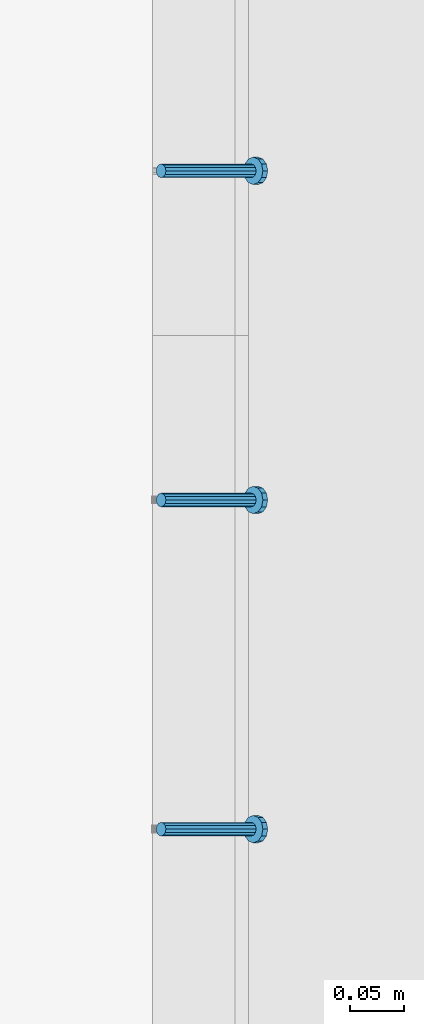
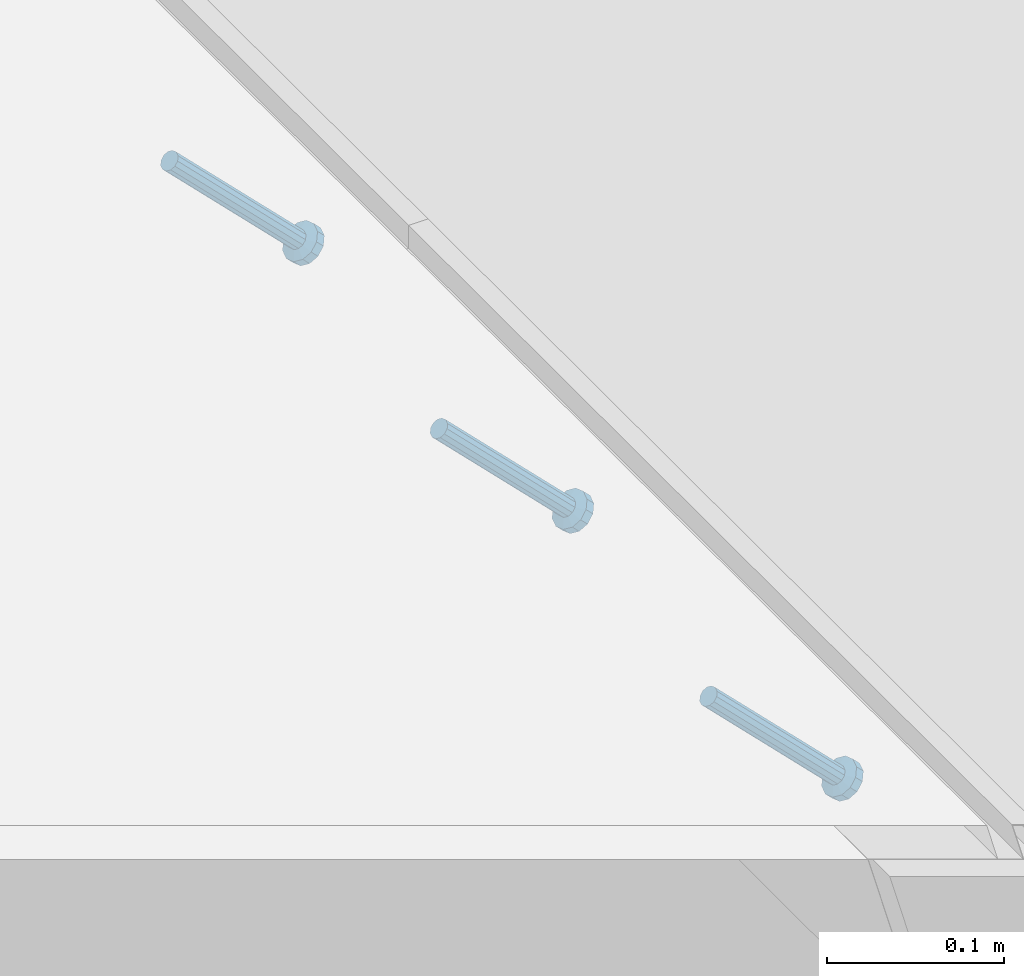
# One storey, part 2380 of 3843: 3 members, 2 elements without a shape of their own.
"""IFC2X3 building model written with IfcOpenShell, lengths in millimetres."""

from ifc_helpers import new_model, si_unit, frame, origin_with_axes, place, context, subcontext, project, spatial, faceted_brep, material, type_object, element, aggregate, save


model = new_model("IFC2X3")

# Units and contexts
model_context = context("Model", 3, precision=1e-05, world=origin_with_axes())
body_context = subcontext(model_context, "Body", "Model", "MODEL_VIEW")
ifc_project = project(units=[si_unit("LENGTHUNIT", "METRE", prefix="MILLI"), si_unit("AREAUNIT", "SQUARE_METRE"), si_unit("VOLUMEUNIT", "CUBIC_METRE"), si_unit("MASSUNIT", "GRAM", prefix="KILO"), si_unit("TIMEUNIT", "SECOND"), si_unit("PLANEANGLEUNIT", "RADIAN"), si_unit("SOLIDANGLEUNIT", "STERADIAN"), si_unit("THERMODYNAMICTEMPERATUREUNIT", "DEGREE_CELSIUS"), si_unit("LUMINOUSINTENSITYUNIT", "LUMEN")], contexts=[model_context])

# Site, building, storey
site_placement = place(None, origin_with_axes())
site = spatial("IfcSite", under=ifc_project, at=site_placement, CompositionType="ELEMENT")
building_placement = place(site_placement, origin_with_axes())
building = spatial("IfcBuilding", under=site, at=building_placement, Name="Undefined", CompositionType="ELEMENT")
storey_placement = place(building_placement, origin_with_axes())
storey = spatial("IfcBuildingStorey", under=building, at=storey_placement, Name="Undefined", CompositionType="ELEMENT", Elevation=0.0)

# Assembly, members
assembly_1_placement = place(storey_placement, origin_with_axes())
assembly_1 = element("IfcElementAssembly", 1, at=assembly_1_placement, inside=storey, Name="EMBED_ANGLE", AssemblyPlace="NOTDEFINED", PredefinedType="RIGID_FRAME")
ifc_material = material(Name="STEEL/A108")
member_type = type_object("IfcMemberType", PredefinedType="NOTDEFINED")
member_1_placement = place(assembly_1_placement, frame((44851.3834999999, 70869.175189209, 30456.1875), z_axis=(0.0, 1.0, 0.0), x_axis=(0.707106781186548, 0.0, -0.707106781186548)))
member_1 = element("IfcMember", 2, at=member_1_placement, type_object=member_type, material=ifc_material, Name="HEADED STUD ANCHOR", context=body_context, shape_type="Brep", body=[
    faceted_brep([(7.27595761418343e-12, -3.18000006675175, 5.5), (0.0, -5.49999999998363, 3.1800000667572), (118.110000000976, -5.49999999999091, 3.1800000667572), (118.110000000983, -3.18000006675175, 5.5), (0.0, -6.3499999046162, 0.0), (118.110000000968, -6.34999990461256, 0.0), (0.0, -5.49999999998363, -3.1800000667572), (118.110000000976, -5.49999999999091, -3.1800000667572), (7.27595761418343e-12, -3.18000006675175, -5.5), (118.110000000983, -3.18000006675175, -5.5), (7.27595761418343e-12, -1.81898940354586e-12, -6.34999990463257), (118.110000000968, -1.81898940354586e-12, -6.34999990463257), (0.0, 3.18000006675175, -5.5), (118.110000000968, 3.18000006674811, -5.5), (7.27595761418343e-12, 5.49999999998363, -3.1800000667572), (118.110000000983, 5.49999999998363, -3.1800000667572), (7.27595761418343e-12, 6.3499999046162, 0.0), (118.110000000976, 6.34999990461256, 0.0), (7.27595761418343e-12, 5.49999999998363, 3.1800000667572), (118.110000000983, 5.49999999998363, 3.1800000667572), (0.0, 3.18000006675175, 5.5), (118.110000000968, 3.18000006674811, 5.5), (7.27595761418343e-12, -1.81898940354586e-12, 6.34999990463257), (118.110000000968, -1.81898940354586e-12, 6.34999990463257), (120.650000000991, -10.9899997710909, 6.34999990463257), (120.650000000998, -6.34000015257152, 10.9899997711182), (120.650000000991, -12.6999998092379, 0.0), (120.650000000991, -10.9899997710909, -6.34999990463257), (120.650000000998, -6.34000015257152, -10.9899997711182), (120.650000000991, -1.81898940354586e-12, -12.6899995803833), (120.650000000991, 6.34000015257152, -10.9899997711182), (120.650000000998, 10.9899997710909, -6.34999990463257), (120.650000000991, 12.6999998092342, 0.0), (120.650000000998, 10.9899997710909, 6.34999990463257), (120.650000000991, 6.34000015257152, 10.9899997711182), (120.650000000991, -1.81898940354586e-12, 12.6899995803833), (127.000000001048, -10.9899997710945, 6.34999990463257), (127.000000001048, -6.34000015257152, 10.9899997711182), (127.000000001048, -12.6999998092342, 0.0), (127.000000001048, -10.9899997710945, -6.34999990463257), (127.000000001048, -6.34000015257152, -10.9899997711182), (127.000000001048, 1.81898940354586e-12, -12.6899995803833), (127.000000001048, 6.34000015256788, -10.9899997711182), (127.000000001048, 10.9899997710909, -6.34999990463257), (127.000000001048, 12.6999998092379, 0.0), (127.000000001048, 10.9899997710909, 6.34999990463257), (127.000000001048, 6.34000015256788, 10.9899997711182), (127.000000001048, 1.81898940354586e-12, 12.6899995803833)], [[[0, 1, 2, 3]], [[1, 4, 5, 2]], [[4, 6, 7, 5]], [[6, 8, 9, 7]], [[8, 10, 11, 9]], [[10, 12, 13, 11]], [[12, 14, 15, 13]], [[14, 16, 17, 15]], [[16, 18, 19, 17]], [[18, 20, 21, 19]], [[20, 22, 23, 21]], [[22, 0, 3, 23]], [[22, 20, 18, 16, 14, 12, 10, 8, 6, 4, 1, 0]], [[3, 2, 24, 25]], [[2, 5, 26, 24]], [[5, 7, 27, 26]], [[7, 9, 28, 27]], [[9, 11, 29, 28]], [[11, 13, 30, 29]], [[13, 15, 31, 30]], [[15, 17, 32, 31]], [[17, 19, 33, 32]], [[19, 21, 34, 33]], [[21, 23, 35, 34]], [[23, 3, 25, 35]], [[25, 24, 36, 37]], [[24, 26, 38, 36]], [[26, 27, 39, 38]], [[27, 28, 40, 39]], [[28, 29, 41, 40]], [[29, 30, 42, 41]], [[30, 31, 43, 42]], [[31, 32, 44, 43]], [[32, 33, 45, 44]], [[33, 34, 46, 45]], [[34, 35, 47, 46]], [[35, 25, 37, 47]], [[38, 39, 40, 41, 42, 43, 44, 45, 46, 47, 37, 36]]]),
])
member_2_placement = place(assembly_1_placement, frame((44851.3834999999, 71173.975189209, 30456.1875), z_axis=(0.0, 1.0, 0.0), x_axis=(0.707106781186548, 0.0, -0.707106781186548)))
member_2 = element("IfcMember", 3, at=member_2_placement, type_object=member_type, material=ifc_material, Name="HEADED STUD ANCHOR", context=body_context, shape_type="Brep", body=[
    faceted_brep([(7.27595761418343e-12, -3.18000006675175, 5.5), (0.0, -5.49999999998363, 3.1800000667572), (118.110000000976, -5.49999999999091, 3.1800000667572), (118.110000000983, -3.18000006675175, 5.5), (0.0, -6.3499999046162, 0.0), (118.110000000968, -6.34999990461256, 0.0), (0.0, -5.49999999998363, -3.1800000667572), (118.110000000976, -5.49999999999091, -3.1800000667572), (7.27595761418343e-12, -3.18000006675175, -5.5), (118.110000000983, -3.18000006675175, -5.5), (7.27595761418343e-12, -1.81898940354586e-12, -6.34999990463257), (118.110000000968, -1.81898940354586e-12, -6.34999990463257), (0.0, 3.18000006675175, -5.5), (118.110000000968, 3.18000006674811, -5.5), (7.27595761418343e-12, 5.49999999998363, -3.1800000667572), (118.110000000983, 5.49999999998363, -3.1800000667572), (7.27595761418343e-12, 6.3499999046162, 0.0), (118.110000000976, 6.34999990461256, 0.0), (7.27595761418343e-12, 5.49999999998363, 3.1800000667572), (118.110000000983, 5.49999999998363, 3.1800000667572), (0.0, 3.18000006675175, 5.5), (118.110000000968, 3.18000006674811, 5.5), (7.27595761418343e-12, -1.81898940354586e-12, 6.34999990463257), (118.110000000968, -1.81898940354586e-12, 6.34999990463257), (120.650000000991, -10.9899997710909, 6.34999990463257), (120.650000000998, -6.34000015257152, 10.9899997711182), (120.650000000991, -12.6999998092379, 0.0), (120.650000000991, -10.9899997710909, -6.34999990463257), (120.650000000998, -6.34000015257152, -10.9899997711182), (120.650000000991, -1.81898940354586e-12, -12.6899995803833), (120.650000000991, 6.34000015257152, -10.9899997711182), (120.650000000998, 10.9899997710909, -6.34999990463257), (120.650000000991, 12.6999998092342, 0.0), (120.650000000998, 10.9899997710909, 6.34999990463257), (120.650000000991, 6.34000015257152, 10.9899997711182), (120.650000000991, -1.81898940354586e-12, 12.6899995803833), (127.000000001048, -10.9899997710945, 6.34999990463257), (127.000000001048, -6.34000015257152, 10.9899997711182), (127.000000001048, -12.6999998092342, 0.0), (127.000000001048, -10.9899997710945, -6.34999990463257), (127.000000001048, -6.34000015257152, -10.9899997711182), (127.000000001048, 1.81898940354586e-12, -12.6899995803833), (127.000000001048, 6.34000015256788, -10.9899997711182), (127.000000001048, 10.9899997710909, -6.34999990463257), (127.000000001048, 12.6999998092379, 0.0), (127.000000001048, 10.9899997710909, 6.34999990463257), (127.000000001048, 6.34000015256788, 10.9899997711182), (127.000000001048, 1.81898940354586e-12, 12.6899995803833)], [[[0, 1, 2, 3]], [[1, 4, 5, 2]], [[4, 6, 7, 5]], [[6, 8, 9, 7]], [[8, 10, 11, 9]], [[10, 12, 13, 11]], [[12, 14, 15, 13]], [[14, 16, 17, 15]], [[16, 18, 19, 17]], [[18, 20, 21, 19]], [[20, 22, 23, 21]], [[22, 0, 3, 23]], [[22, 20, 18, 16, 14, 12, 10, 8, 6, 4, 1, 0]], [[3, 2, 24, 25]], [[2, 5, 26, 24]], [[5, 7, 27, 26]], [[7, 9, 28, 27]], [[9, 11, 29, 28]], [[11, 13, 30, 29]], [[13, 15, 31, 30]], [[15, 17, 32, 31]], [[17, 19, 33, 32]], [[19, 21, 34, 33]], [[21, 23, 35, 34]], [[23, 3, 25, 35]], [[25, 24, 36, 37]], [[24, 26, 38, 36]], [[26, 27, 39, 38]], [[27, 28, 40, 39]], [[28, 29, 41, 40]], [[29, 30, 42, 41]], [[30, 31, 43, 42]], [[31, 32, 44, 43]], [[32, 33, 45, 44]], [[33, 34, 46, 45]], [[34, 35, 47, 46]], [[35, 25, 37, 47]], [[38, 39, 40, 41, 42, 43, 44, 45, 46, 47, 37, 36]]]),
])
aggregate(assembly_1, [member_1, member_2])

# Assembly, member
assembly_2_placement = place(storey_placement, origin_with_axes())
assembly_2 = element("IfcElementAssembly", 4, at=assembly_2_placement, inside=storey, Name="EMBED_ANGLE", AssemblyPlace="NOTDEFINED", PredefinedType="RIGID_FRAME")
member_3_placement = place(assembly_2_placement, frame((44851.3834999999, 71478.775189209, 30456.1875), z_axis=(0.0, 1.0, 0.0), x_axis=(0.707106781186548, 0.0, -0.707106781186548)))
member_3 = element("IfcMember", 5, at=member_3_placement, type_object=member_type, material=ifc_material, Name="HEADED STUD ANCHOR", context=body_context, shape_type="Brep", body=[
    faceted_brep([(7.27595761418343e-12, -3.18000006675175, 5.5), (0.0, -5.49999999998363, 3.1800000667572), (118.110000000976, -5.49999999999091, 3.1800000667572), (118.110000000983, -3.18000006675175, 5.5), (0.0, -6.3499999046162, 0.0), (118.110000000968, -6.34999990461256, 0.0), (0.0, -5.49999999998363, -3.1800000667572), (118.110000000976, -5.49999999999091, -3.1800000667572), (7.27595761418343e-12, -3.18000006675175, -5.5), (118.110000000983, -3.18000006675175, -5.5), (7.27595761418343e-12, -1.81898940354586e-12, -6.34999990463257), (118.110000000968, -1.81898940354586e-12, -6.34999990463257), (0.0, 3.18000006675175, -5.5), (118.110000000968, 3.18000006674811, -5.5), (7.27595761418343e-12, 5.49999999998363, -3.1800000667572), (118.110000000983, 5.49999999998363, -3.1800000667572), (7.27595761418343e-12, 6.3499999046162, 0.0), (118.110000000976, 6.34999990461256, 0.0), (7.27595761418343e-12, 5.49999999998363, 3.1800000667572), (118.110000000983, 5.49999999998363, 3.1800000667572), (0.0, 3.18000006675175, 5.5), (118.110000000968, 3.18000006674811, 5.5), (7.27595761418343e-12, -1.81898940354586e-12, 6.34999990463257), (118.110000000968, -1.81898940354586e-12, 6.34999990463257), (120.650000000991, -10.9899997710909, 6.34999990463257), (120.650000000998, -6.34000015257152, 10.9899997711182), (120.650000000991, -12.6999998092379, 0.0), (120.650000000991, -10.9899997710909, -6.34999990463257), (120.650000000998, -6.34000015257152, -10.9899997711182), (120.650000000991, -1.81898940354586e-12, -12.6899995803833), (120.650000000991, 6.34000015257152, -10.9899997711182), (120.650000000998, 10.9899997710909, -6.34999990463257), (120.650000000991, 12.6999998092342, 0.0), (120.650000000998, 10.9899997710909, 6.34999990463257), (120.650000000991, 6.34000015257152, 10.9899997711182), (120.650000000991, -1.81898940354586e-12, 12.6899995803833), (127.000000001048, -10.9899997710945, 6.34999990463257), (127.000000001048, -6.34000015257152, 10.9899997711182), (127.000000001048, -12.6999998092342, 0.0), (127.000000001048, -10.9899997710945, -6.34999990463257), (127.000000001048, -6.34000015257152, -10.9899997711182), (127.000000001048, 1.81898940354586e-12, -12.6899995803833), (127.000000001048, 6.34000015256788, -10.9899997711182), (127.000000001048, 10.9899997710909, -6.34999990463257), (127.000000001048, 12.6999998092379, 0.0), (127.000000001048, 10.9899997710909, 6.34999990463257), (127.000000001048, 6.34000015256788, 10.9899997711182), (127.000000001048, 1.81898940354586e-12, 12.6899995803833)], [[[0, 1, 2, 3]], [[1, 4, 5, 2]], [[4, 6, 7, 5]], [[6, 8, 9, 7]], [[8, 10, 11, 9]], [[10, 12, 13, 11]], [[12, 14, 15, 13]], [[14, 16, 17, 15]], [[16, 18, 19, 17]], [[18, 20, 21, 19]], [[20, 22, 23, 21]], [[22, 0, 3, 23]], [[22, 20, 18, 16, 14, 12, 10, 8, 6, 4, 1, 0]], [[3, 2, 24, 25]], [[2, 5, 26, 24]], [[5, 7, 27, 26]], [[7, 9, 28, 27]], [[9, 11, 29, 28]], [[11, 13, 30, 29]], [[13, 15, 31, 30]], [[15, 17, 32, 31]], [[17, 19, 33, 32]], [[19, 21, 34, 33]], [[21, 23, 35, 34]], [[23, 3, 25, 35]], [[25, 24, 36, 37]], [[24, 26, 38, 36]], [[26, 27, 39, 38]], [[27, 28, 40, 39]], [[28, 29, 41, 40]], [[29, 30, 42, 41]], [[30, 31, 43, 42]], [[31, 32, 44, 43]], [[32, 33, 45, 44]], [[33, 34, 46, 45]], [[34, 35, 47, 46]], [[35, 25, 37, 47]], [[38, 39, 40, 41, 42, 43, 44, 45, 46, 47, 37, 36]]]),
])
aggregate(assembly_2, [member_3])

save(model, "model.ifc")
